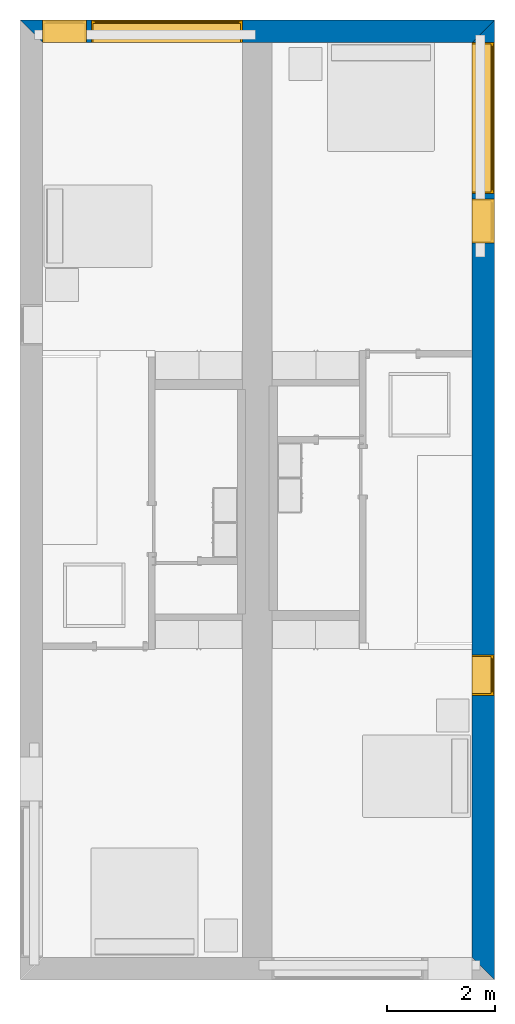
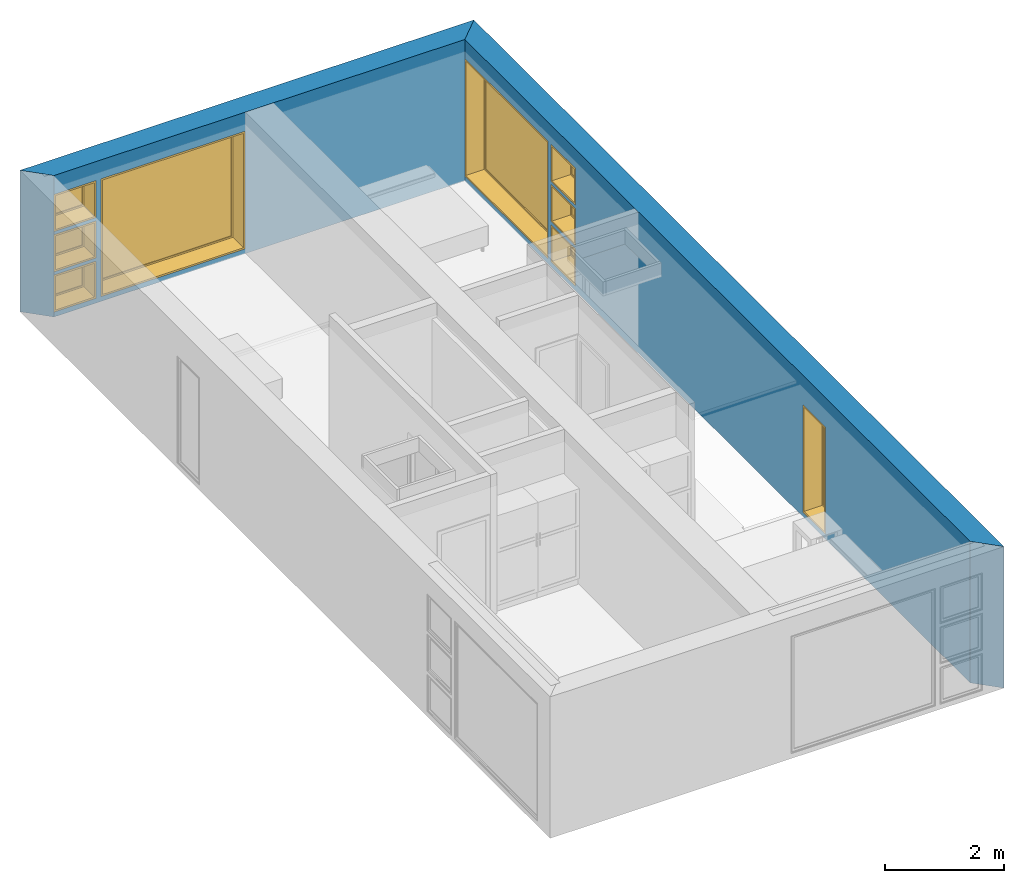
# One storey, part 4 of 16: 9 windows, 2 walls, 9 openings.
"""IFC2X3 building model written with IfcOpenShell, lengths in metres."""

from ifc_helpers import new_model, entity, si_unit, converted_unit, frame, frame_2d, origin, origin_2d_with_axis, place, context, project, spatial, polyline, rectangle, outline, extrude, source, transform, mapped, material, layer, layer_set, layer_usage, type_object, type_shapes, element, fill, save


model = new_model("IFC2X3")

# Units and contexts
model_context = context("Model", 3, precision=1e-09, world=origin())
plan_context = context("Plan", 3, precision=1e-09, world=origin())
ifc_project = project(units=[si_unit("LENGTHUNIT", "METRE"), si_unit("AREAUNIT", "SQUARE_METRE"), si_unit("VOLUMEUNIT", "CUBIC_METRE"), converted_unit("PLANEANGLEUNIT", "DEGREE", entity("IfcRatioMeasure", 0.01745329251994328), si_unit("PLANEANGLEUNIT", "RADIAN"), dimensions=[0, 0, 0, 0, 0, 0, 0]), si_unit("TIMEUNIT", "SECOND")], contexts=[model_context, plan_context])

# Site, building, storey
site_placement = place(None, origin())
site = spatial("IfcSite", under=ifc_project, at=site_placement, CompositionType="ELEMENT")
building_placement = place(site_placement, origin())
building = spatial("IfcBuilding", under=site, at=building_placement, CompositionType="ELEMENT")
storey_placement = place(building_placement, frame((0.0, 0.0, 3.100000000000378)))
storey = spatial("IfcBuildingStorey", under=building, at=storey_placement, Name="Level 2", CompositionType="ELEMENT", Elevation=3.100000000000378)

# Wall, openings, windows
ifc_material_1 = material(Name="Masonry - Brick")
ifc_layer_1 = layer(ifc_material_1, 0.092)
ifc_material_2 = material(Name="Misc. Air Layers - Air Space")
ifc_layer_2 = layer(ifc_material_2, 0.025)
ifc_material_3 = material(Name="Insulation / Thermal Barriers - Rigid insulation")
ifc_layer_3 = layer(ifc_material_3, 0.05)
ifc_material_4 = material(Name="Masonry - Concrete Block")
ifc_layer_4 = layer(ifc_material_4, 0.193)
ifc_material_5 = material(Name="Metal - Stud Layer")
ifc_layer_5 = layer(ifc_material_5, 0.041)
ifc_material_6 = material(Name="Plasterboard")
ifc_layer_6 = layer(ifc_material_6, 0.016)
ifc_layer_set = layer_set([ifc_layer_1, ifc_layer_2, ifc_layer_3, ifc_layer_4, ifc_layer_5, ifc_layer_6], Name="Basic Wall:Exterior - Brick on Block")
ifc_layer_usage_1 = layer_usage(ifc_layer_set, "AXIS2", "NEGATIVE", 0.2085000000000001)
wall_1_placement = place(storey_placement, frame((0.0, -0.2085000000000001, 0.0)))
wall_1 = element("IfcWallStandardCase", 1, at=wall_1_placement, inside=storey, material=ifc_layer_usage_1, Name="Basic Wall:Exterior - Brick on Block", ObjectType="Basic Wall:Exterior - Brick on Block", context=model_context, shape_type="SweptSolid", body=[
    extrude(outline(polyline([(8.383000000000001, -0.2085000000000001), (8.8, 0.2085000000000001), (0.0, 0.2085000000000001), (0.4170000000000014, -0.2085000000000001), (4.125000000000002, -0.2085000000000001), (4.675000000000002, -0.2085000000000001), (8.383000000000001, -0.2085000000000001)])), origin(), (0.0, 0.0, 1.0), 2.900000000000012),
])
opening_1_placement = place(wall_1_placement, frame((1.325, -0.2084999999999999, 0.09999999999981862)))
opening_1 = element("IfcOpeningElement", 2, at=opening_1_placement, cuts=wall_1, ObjectType="Opening", context=model_context, shape_type="SweptSolid", body=[
    extrude(rectangle(XDim=2.409999999999996, YDim=2.8, at=frame_2d((1.204999999999998, 1.4), x_axis=(1.0, 0.0))), frame((0.0, 0.0, 0.0), z_axis=(0.0, 1.0, 0.0), x_axis=(0.0, 0.0, 1.0)), (0.0, 0.0, 1.0), 0.4170000000000001),
])
opening_2_placement = place(wall_1_placement, frame((0.4170000000000003, -0.2085000000000001, 0.0999999999998235)))
opening_2 = element("IfcOpeningElement", 3, at=opening_2_placement, cuts=wall_1, ObjectType="Opening", context=model_context, shape_type="SweptSolid", body=[
    extrude(rectangle(XDim=0.7589999999999981, YDim=0.8189999999999996, at=frame_2d((0.379499999999999, 0.4095), x_axis=(1.0, 0.0))), frame((0.0, 0.0, 0.0), z_axis=(0.0, 1.0, 0.0), x_axis=(0.0, 0.0, 1.0)), (0.0, 0.0, 1.0), 0.4170000000000001),
])
opening_3_placement = place(wall_1_placement, frame((0.417000000000015, -0.2085000000000014, 0.9254999999998172)))
opening_3 = element("IfcOpeningElement", 4, at=opening_3_placement, cuts=wall_1, ObjectType="Opening", context=model_context, shape_type="SweptSolid", body=[
    extrude(rectangle(XDim=0.7590000000000007, YDim=0.8189999999999998, at=frame_2d((0.3795000000000003, 0.4094999999999999), x_axis=(-1.0, 0.0))), frame((0.0, 0.0, 0.0), z_axis=(0.0, 1.0, 0.0), x_axis=(0.0, 0.0, 1.0)), (0.0, 0.0, 1.0), 0.4170000000000001),
])
opening_4_placement = place(wall_1_placement, frame((0.4170000000000002, -0.2085000000000001, 1.750999999999816)))
opening_4 = element("IfcOpeningElement", 5, at=opening_4_placement, cuts=wall_1, ObjectType="Opening", context=model_context, shape_type="SweptSolid", body=[
    extrude(rectangle(XDim=0.7589999999999981, YDim=0.8189999999999995, at=frame_2d((0.3794999999999993, 0.4094999999999998), x_axis=(1.0, 0.0))), frame((0.0, 0.0, 0.0), z_axis=(0.0, 1.0, 0.0), x_axis=(0.0, 0.0, 1.0)), (0.0, 0.0, 1.0), 0.4170000000000001),
])
window_style_1 = type_object("IfcWindowStyle", Name="2800mm x 2410mm", ConstructionType="NOTDEFINED", OperationType="NOTDEFINED", ParameterTakesPrecedence=False, Sizeable=False)
shared_shape_1 = source(origin(), model_context, "Body", "SweptSolid", [
    extrude(rectangle(XDim=0.01199999999999998, YDim=2.673999999999997, at=origin_2d_with_axis()), frame((1.400000000000007, 0.3759999999999956, 0.06299999999998514), z_axis=(0.0, 0.0, 1.0), x_axis=(0.0, -1.0, 0.0)), (0.0, 0.0, 1.0), 2.284000000000005),
    extrude(outline(polyline([(-1.381, -1.186000000000001), (1.381, -1.186000000000001), (1.381, 1.186000000000001), (-1.381, 1.186000000000001), (-1.381, -1.186000000000001)]), holes=[polyline([(-1.336999999999999, -1.142000000000002), (-1.336999999999999, 1.142000000000003), (1.336999999999997, 1.142000000000003), (1.336999999999997, -1.142000000000002), (-1.336999999999999, -1.142000000000002)])]), frame((1.400000000000008, 0.3539999999999681, 1.204999999999988), z_axis=(0.0, 1.0, 0.0), x_axis=(1.0, 0.0, 0.0)), (0.0, 0.0, 1.0), 0.04400000000002743),
    extrude(outline(polyline([(-1.4, -1.204999999999996), (1.4, -1.204999999999996), (1.4, 1.204999999999996), (-1.4, 1.204999999999996), (-1.4, -1.204999999999996)]), holes=[polyline([(-1.381000000000001, -1.185999999999981), (-1.381000000000001, 1.186000000000022), (1.380999999999999, 1.186000000000022), (1.380999999999999, -1.185999999999981), (-1.381000000000001, -1.185999999999981)])]), frame((1.400000000000009, 0.3539999999999681, 1.205000000000009), z_axis=(0.0, 1.0, 0.0), x_axis=(1.0, 0.0, 0.0)), (0.0, 0.0, 1.0), 0.06300000000002744),
    extrude(outline(polyline([(-1.4, -1.204999999999995), (1.4, -1.204999999999995), (1.4, 1.204999999999995), (-1.4, 1.204999999999995), (-1.4, -1.204999999999995)]), holes=[polyline([(-1.368, -1.172999999999982), (-1.368, 1.17300000000002), (1.368, 1.17300000000002), (1.367999999999999, -1.172999999999982), (-1.368, -1.172999999999982)])]), frame((1.40000000000001, 0.0, 1.205000000000008), z_axis=(0.0, 1.0, 0.0), x_axis=(1.0, 0.0, 0.0)), (0.0, 0.0, 1.0), 0.3539999999999727),
])
type_shapes(window_style_1, [shared_shape_1])
window_1_placement = place(opening_1_placement, origin())
window_1 = element("IfcWindow", 6, at=window_1_placement, inside=storey, type_object=window_style_1, ObjectType="2800mm x 2410mm", OverallHeight=2.409999999999996, OverallWidth=2.8, context=model_context, shape_type="MappedRepresentation", body=[
    mapped(shared_shape_1, transform((0.0, 0.0, 0.0), scale=1.0)),
])
fill(opening_1, window_1)
window_style_2 = type_object("IfcWindowStyle", Name="819mm x 759mm", ConstructionType="NOTDEFINED", OperationType="NOTDEFINED", ParameterTakesPrecedence=False, Sizeable=False)
shared_shape_2 = source(origin(), model_context, "Body", "SweptSolid", [
    extrude(rectangle(XDim=0.01199999999999998, YDim=0.6929999999999971, at=origin_2d_with_axis()), frame((0.4095000000000068, 0.3759999999999988, 0.06299999999998514), z_axis=(0.0, 0.0, 1.0), x_axis=(0.0, -1.0, 0.0)), (0.0, 0.0, 1.0), 0.6330000000000073),
    extrude(outline(polyline([(-0.3904999999999999, -0.3605000000000028), (0.3904999999999999, -0.3605000000000028), (0.3904999999999999, 0.3605000000000027), (-0.3904999999999999, 0.3605000000000027), (-0.3904999999999999, -0.3605000000000028)]), holes=[polyline([(-0.3464999999999996, -0.3165000000000033), (-0.3464999999999996, 0.316500000000004), (0.3464999999999974, 0.316500000000004), (0.3464999999999974, -0.3165000000000033), (-0.3464999999999996, -0.3165000000000033)])]), frame((0.4095000000000078, 0.3539999999999714, 0.3794999999999891), z_axis=(0.0, 1.0, 0.0), x_axis=(1.0, 0.0, 0.0)), (0.0, 0.0, 1.0), 0.04400000000002743),
    extrude(outline(polyline([(-0.4094999999999998, -0.3794999999999972), (0.4094999999999998, -0.3794999999999972), (0.4094999999999998, 0.3794999999999971), (-0.4094999999999998, 0.3794999999999971), (-0.4094999999999998, -0.3794999999999972)]), holes=[polyline([(-0.3905000000000011, -0.3604999999999823), (-0.3905000000000012, 0.3605000000000231), (0.3904999999999986, 0.3605000000000231), (0.3904999999999987, -0.3604999999999823), (-0.3905000000000011, -0.3604999999999823)])]), frame((0.4095000000000091, 0.3539999999999714, 0.3795000000000096), z_axis=(0.0, 1.0, 0.0), x_axis=(1.0, 0.0, 0.0)), (0.0, 0.0, 1.0), 0.06300000000002744),
    extrude(outline(polyline([(-0.4095000000000002, -0.3794999999999967), (0.4095000000000002, -0.3794999999999967), (0.4095000000000002, 0.3794999999999966), (-0.4095000000000002, 0.3794999999999966), (-0.4095000000000002, -0.3794999999999967)]), holes=[polyline([(-0.3774999999999999, -0.3474999999999832), (-0.3774999999999999, 0.3475000000000212), (0.3775000000000001, 0.3475000000000212), (0.3775000000000001, -0.3474999999999832), (-0.3774999999999999, -0.3474999999999832)])]), frame((0.4095000000000096, 0.0, 0.379500000000009), z_axis=(0.0, 1.0, 0.0), x_axis=(1.0, 0.0, 0.0)), (0.0, 0.0, 1.0), 0.3539999999999727),
])
type_shapes(window_style_2, [shared_shape_2])
window_2_placement = place(opening_2_placement, origin())
window_2 = element("IfcWindow", 7, at=window_2_placement, inside=storey, type_object=window_style_2, ObjectType="819mm x 759mm", OverallHeight=0.758999999999998, OverallWidth=0.8189999999999998, context=model_context, shape_type="MappedRepresentation", body=[
    mapped(shared_shape_2, transform((0.0, 0.0, 0.0), scale=1.0)),
])
fill(opening_2, window_2)
window_3_placement = place(opening_4_placement, origin())
window_3 = element("IfcWindow", 8, at=window_3_placement, inside=storey, type_object=window_style_2, ObjectType="819mm x 759mm", OverallHeight=0.7589999999999986, OverallWidth=0.8189999999999995, context=model_context, shape_type="MappedRepresentation", body=[
    mapped(shared_shape_2, transform((0.0, 0.0, 0.0), scale=1.0)),
])
fill(opening_4, window_3)
window_style_3 = type_object("IfcWindowStyle", Name="819mm x 759mm", ConstructionType="NOTDEFINED", OperationType="NOTDEFINED", ParameterTakesPrecedence=False, Sizeable=False)
shared_shape_3 = source(origin(), model_context, "Body", "SweptSolid", [
    extrude(rectangle(XDim=0.01269999999999999, YDim=0.6919999999999978, at=origin_2d_with_axis()), frame((0.4095000000000003, 0.3757750000000001, 0.06350000000000397), z_axis=(0.0, 0.0, 1.0), x_axis=(0.0, 1.0, 0.0)), (0.0, 0.0, 1.0), 0.6320000000000041),
    extrude(outline(polyline([(-0.3904499999999989, -0.3604500000000012), (0.3904499999999989, -0.3604500000000012), (0.3904499999999989, 0.3604500000000012), (-0.3904499999999989, 0.3604500000000012), (-0.3904499999999989, -0.3604500000000012)]), holes=[polyline([(-0.3459999999999978, -0.3160000000000016), (-0.3459999999999978, 0.3160000000000026), (0.346, 0.3160000000000026), (0.346, -0.3160000000000016), (-0.3459999999999978, -0.3160000000000016)])]), frame((0.4094999999999992, 0.3535500000000001, 0.3795000000000066), z_axis=(0.0, 1.0, 0.0), x_axis=(1.0, 0.0, 0.0)), (0.0, 0.0, 1.0), 0.04445),
    extrude(outline(polyline([(-0.4094999999999992, -0.3795000000000012), (0.4094999999999992, -0.3795000000000012), (0.4094999999999992, 0.3795000000000012), (-0.4094999999999992, 0.3795000000000012), (-0.4094999999999992, -0.3795000000000012)]), holes=[polyline([(-0.3777500000000001, -0.3477499999999997), (-0.3777500000000001, 0.3477500000000008), (0.3777499999999982, 0.3477500000000008), (0.3777499999999982, -0.3477499999999997), (-0.3777500000000001, -0.3477499999999997)])]), frame((0.4095000000000007, 0.0, 0.3795000000000077), z_axis=(0.0, 1.0, 0.0), x_axis=(1.0, 0.0, 0.0)), (0.0, 0.0, 1.0), 0.3535500000000001),
    extrude(outline(polyline([(-0.3795000000000017, -0.4094999999999995), (0.3795000000000017, -0.4094999999999995), (0.3795000000000017, 0.4094999999999995), (-0.3795000000000017, 0.4094999999999995), (-0.3795000000000017, -0.4094999999999995)]), holes=[polyline([(-0.3604500000000023, -0.3904499999999987), (-0.3604500000000023, 0.3904499999999997), (0.3604500000000017, 0.3904499999999997), (0.3604500000000017, -0.3904499999999988), (-0.3604500000000023, -0.3904499999999987)])]), frame((0.4095000000000004, 0.3535500000000001, 0.3795000000000071), z_axis=(0.0, 1.0, 0.0), x_axis=(0.0, 0.0, -1.0)), (0.0, 0.0, 1.0), 0.06345),
])
type_shapes(window_style_3, [shared_shape_3])
window_4_placement = place(opening_3_placement, origin())
window_4 = element("IfcWindow", 9, at=window_4_placement, inside=storey, type_object=window_style_3, ObjectType="819mm x 759mm", OverallHeight=0.7590000000000007, OverallWidth=0.819, context=model_context, shape_type="MappedRepresentation", body=[
    mapped(shared_shape_3, transform((0.0, 0.0, 0.0), scale=1.0)),
])
fill(opening_3, window_4)

ifc_layer_usage_2 = layer_usage(ifc_layer_set, "AXIS2", "NEGATIVE", 0.2085000000000001)
wall_2_placement = place(storey_placement, frame((8.5915, 0.0, 0.0), z_axis=(0.0, 0.0, 1.0), x_axis=(0.0, -1.0, 0.0)))
wall_2 = element("IfcWallStandardCase", 10, at=wall_2_placement, inside=storey, material=ifc_layer_usage_2, Name="Basic Wall:Exterior - Brick on Block", ObjectType="Basic Wall:Exterior - Brick on Block", context=model_context, shape_type="SweptSolid", body=[
    extrude(outline(polyline([(17.38299999999997, -0.2084999999999999), (17.79999999999997, 0.2085000000000002), (0.0, 0.2085000000000002), (0.4169999999999991, -0.2085000000000007), (6.125999999999979, -0.2084999999999999), (6.24999999999998, -0.2084999999999997), (17.38299999999997, -0.2084999999999999)])), origin(), (0.0, 0.0, 1.0), 2.900000000000012),
])
opening_5_placement = place(wall_2_placement, frame((0.4170000000000265, -0.2084999999999953, 0.09999999999981862)))
opening_5 = element("IfcOpeningElement", 11, at=opening_5_placement, cuts=wall_2, ObjectType="Opening", context=model_context, shape_type="SweptSolid", body=[
    extrude(rectangle(XDim=2.409999999999996, YDim=2.8, at=frame_2d((1.204999999999998, 1.4), x_axis=(1.0, 0.0))), frame((0.0, 0.0, 0.0), z_axis=(0.0, 1.0, 0.0), x_axis=(0.0, 0.0, 1.0)), (0.0, 0.0, 1.0), 0.4170000000000001),
])
opening_6_placement = place(wall_2_placement, frame((3.317000000000027, -0.2085000000000039, 1.750999999999819)))
opening_6 = element("IfcOpeningElement", 12, at=opening_6_placement, cuts=wall_2, ObjectType="Opening", context=model_context, shape_type="SweptSolid", body=[
    extrude(rectangle(XDim=0.7589999999999981, YDim=0.8189999999999995, at=frame_2d((0.379499999999999, 0.4094999999999998), x_axis=(1.0, 0.0))), frame((0.0, 0.0, 0.0), z_axis=(0.0, 1.0, 0.0), x_axis=(0.0, 0.0, 1.0)), (0.0, 0.0, 1.0), 0.4170000000000001),
])
opening_7_placement = place(wall_2_placement, frame((3.317000000000042, -0.2085000000000054, 0.9254999999998184)))
opening_7 = element("IfcOpeningElement", 13, at=opening_7_placement, cuts=wall_2, ObjectType="Opening", context=model_context, shape_type="SweptSolid", body=[
    extrude(rectangle(XDim=0.7590000000000007, YDim=0.8189999999999998, at=frame_2d((0.3795000000000003, 0.4094999999999999), x_axis=(-1.0, 0.0))), frame((0.0, 0.0, 0.0), z_axis=(0.0, 1.0, 0.0), x_axis=(0.0, 0.0, 1.0)), (0.0, 0.0, 1.0), 0.4170000000000001),
])
opening_8_placement = place(wall_2_placement, frame((3.317000000000027, -0.2085000000000039, 0.09999999999981862)))
opening_8 = element("IfcOpeningElement", 14, at=opening_8_placement, cuts=wall_2, ObjectType="Opening", context=model_context, shape_type="SweptSolid", body=[
    extrude(rectangle(XDim=0.7589999999999981, YDim=0.8189999999999995, at=frame_2d((0.3794999999999993, 0.4094999999999998), x_axis=(1.0, 0.0))), frame((0.0, 0.0, 0.0), z_axis=(0.0, 1.0, 0.0), x_axis=(0.0, 0.0, 1.0)), (0.0, 0.0, 1.0), 0.4170000000000001),
])
opening_9_placement = place(wall_2_placement, frame((11.774, -0.2085000000000172, 0.09999999999981862)))
opening_9 = element("IfcOpeningElement", 15, at=opening_9_placement, cuts=wall_2, ObjectType="Opening", context=model_context, shape_type="SweptSolid", body=[
    extrude(rectangle(XDim=2.199999999999996, YDim=0.7499999999999996, at=frame_2d((1.099999999999999, 0.3749999999999987), x_axis=(1.0, 0.0))), frame((0.0, 0.0, 0.0), z_axis=(0.0, 1.0, 0.0), x_axis=(0.0, 0.0, 1.0)), (0.0, 0.0, 1.0), 0.4170000000000001),
])
window_style_4 = type_object("IfcWindowStyle", Name="750mm x 2200mm", ConstructionType="NOTDEFINED", OperationType="NOTDEFINED", ParameterTakesPrecedence=False, Sizeable=False)
shared_shape_4 = source(origin(), model_context, "Body", "SweptSolid", [
    extrude(rectangle(XDim=0.01199999999999998, YDim=0.623999999999997, at=origin_2d_with_axis()), frame((0.375000000000007, 0.3759999999999988, 0.06299999999998514), z_axis=(0.0, 0.0, 1.0), x_axis=(0.0, -1.0, 0.0)), (0.0, 0.0, 1.0), 2.074000000000006),
    extrude(outline(polyline([(-0.3559999999999999, -1.081000000000002), (0.3559999999999999, -1.081000000000002), (0.3559999999999999, 1.081000000000002), (-0.3559999999999999, 1.081000000000002), (-0.3559999999999999, -1.081000000000002)]), holes=[polyline([(-0.3119999999999996, -1.037000000000002), (-0.3119999999999996, 1.037000000000003), (0.3119999999999975, 1.037000000000003), (0.3119999999999975, -1.037000000000002), (-0.3119999999999996, -1.037000000000002)])]), frame((0.3750000000000081, 0.3539999999999715, 1.099999999999989), z_axis=(0.0, 1.0, 0.0), x_axis=(1.0, 0.0, 0.0)), (0.0, 0.0, 1.0), 0.04400000000002743),
    extrude(outline(polyline([(-0.3749999999999997, -1.099999999999996), (0.3749999999999997, -1.099999999999996), (0.3749999999999997, 1.099999999999996), (-0.3749999999999997, 1.099999999999996), (-0.3749999999999997, -1.099999999999996)]), holes=[polyline([(-0.3560000000000012, -1.080999999999981), (-0.3560000000000013, 1.081000000000022), (0.3559999999999985, 1.081000000000022), (0.3559999999999986, -1.080999999999981), (-0.3560000000000012, -1.080999999999981)])]), frame((0.3750000000000094, 0.3539999999999715, 1.100000000000009), z_axis=(0.0, 1.0, 0.0), x_axis=(1.0, 0.0, 0.0)), (0.0, 0.0, 1.0), 0.06300000000002744),
    extrude(outline(polyline([(-0.3750000000000001, -1.099999999999996), (0.3750000000000001, -1.099999999999996), (0.3750000000000001, 1.099999999999996), (-0.3750000000000001, 1.099999999999996), (-0.3750000000000001, -1.099999999999996)]), holes=[polyline([(-0.3429999999999999, -1.067999999999982), (-0.3429999999999999, 1.06800000000002), (0.3430000000000001, 1.06800000000002), (0.3430000000000001, -1.067999999999982), (-0.3429999999999999, -1.067999999999982)])]), frame((0.3750000000000099, 0.0, 1.100000000000008), z_axis=(0.0, 1.0, 0.0), x_axis=(1.0, 0.0, 0.0)), (0.0, 0.0, 1.0), 0.3539999999999727),
])
type_shapes(window_style_4, [shared_shape_4])
window_5_placement = place(opening_9_placement, origin())
window_5 = element("IfcWindow", 16, at=window_5_placement, inside=storey, type_object=window_style_4, ObjectType="750mm x 2200mm", OverallHeight=2.199999999999997, OverallWidth=0.7499999999999984, context=model_context, shape_type="MappedRepresentation", body=[
    mapped(shared_shape_4, transform((0.0, 0.0, 0.0), scale=1.0)),
])
fill(opening_9, window_5)
window_6_placement = place(opening_5_placement, origin())
window_6 = element("IfcWindow", 17, at=window_6_placement, inside=storey, type_object=window_style_1, ObjectType="2800mm x 2410mm", OverallHeight=2.409999999999996, OverallWidth=2.8, context=model_context, shape_type="MappedRepresentation", body=[
    mapped(shared_shape_1, transform((0.0, 0.0, 0.0), scale=1.0)),
])
fill(opening_5, window_6)
window_7_placement = place(opening_6_placement, origin())
window_7 = element("IfcWindow", 18, at=window_7_placement, inside=storey, type_object=window_style_2, ObjectType="819mm x 759mm", OverallHeight=0.758999999999998, OverallWidth=0.8189999999999995, context=model_context, shape_type="MappedRepresentation", body=[
    mapped(shared_shape_2, transform((0.0, 0.0, 0.0), scale=1.0)),
])
fill(opening_6, window_7)
window_8_placement = place(opening_8_placement, origin())
window_8 = element("IfcWindow", 19, at=window_8_placement, inside=storey, type_object=window_style_2, ObjectType="819mm x 759mm", OverallHeight=0.7589999999999986, OverallWidth=0.8189999999999995, context=model_context, shape_type="MappedRepresentation", body=[
    mapped(shared_shape_2, transform((0.0, 0.0, 0.0), scale=1.0)),
])
fill(opening_8, window_8)
window_9_placement = place(opening_7_placement, origin())
window_9 = element("IfcWindow", 20, at=window_9_placement, inside=storey, type_object=window_style_3, ObjectType="819mm x 759mm", OverallHeight=0.7590000000000007, OverallWidth=0.8190000000000001, context=model_context, shape_type="MappedRepresentation", body=[
    mapped(shared_shape_3, transform((0.0, 0.0, 0.0), scale=1.0)),
])
fill(opening_7, window_9)

save(model, "model.ifc")
